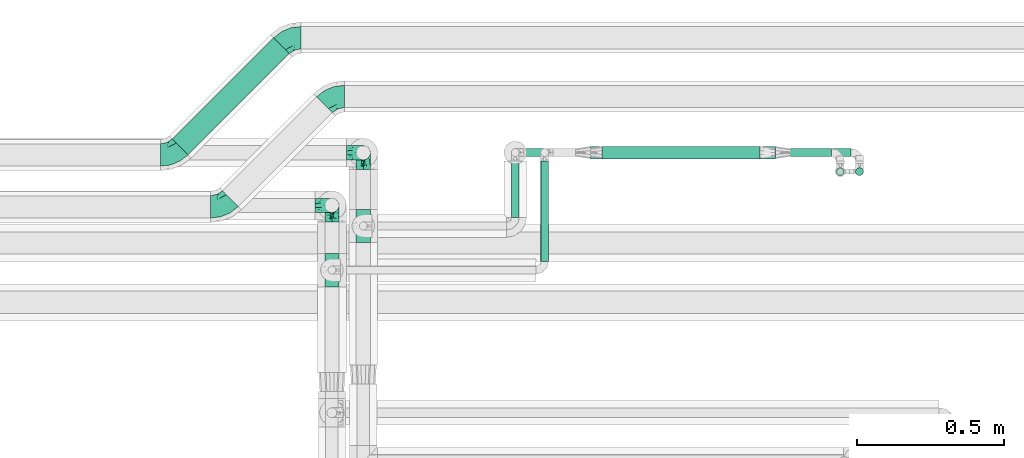
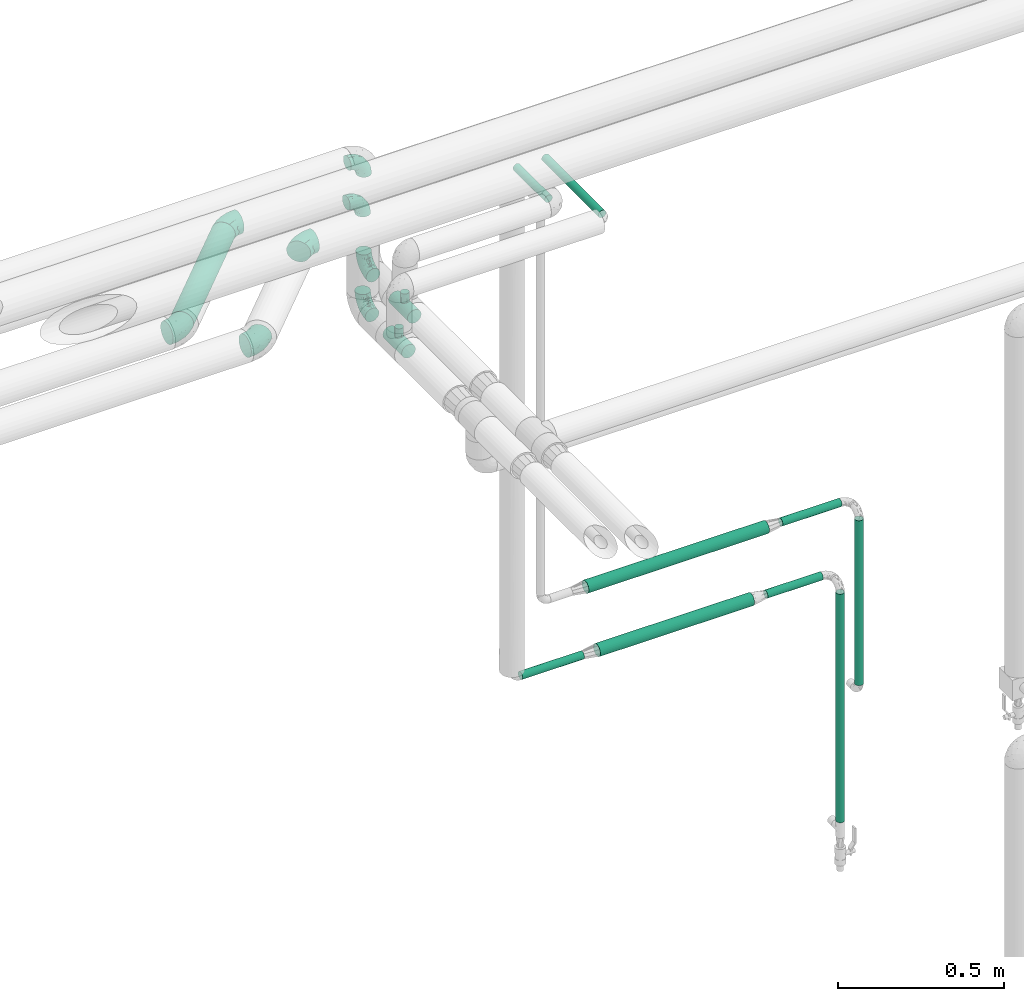
# One storey, part 655 of 827: 10 flow fittings, 10 flow segments.
"""IFC2X3 building model written with IfcOpenShell, lengths in millimetres."""

from ifc_helpers import new_model, entity, si_unit, converted_unit, derived_unit, direction, frame, origin, origin_2d_with_axis, place, context, subcontext, project, spatial, circle, extrude, faceted_brep, source, transform, mapped, material, type_object, type_shapes, element, save


model = new_model("IFC2X3")

# Units and contexts
model_context = context("Model", 3, precision=0.01, world=origin(), true_north=direction((6.12303176911189e-17, 1.0)))
body_context = subcontext(model_context, "Body", "Model", "MODEL_VIEW")
ifc_project = project(units=[si_unit("LENGTHUNIT", "METRE", prefix="MILLI"), si_unit("AREAUNIT", "SQUARE_METRE"), si_unit("VOLUMEUNIT", "CUBIC_METRE"), converted_unit("PLANEANGLEUNIT", "DEGREE", entity("IfcRatioMeasure", 0.0174532925199433), si_unit("PLANEANGLEUNIT", "RADIAN"), dimensions=[0, 0, 0, 0, 0, 0, 0]), si_unit("MASSUNIT", "GRAM", prefix="KILO"), derived_unit("MASSDENSITYUNIT", [(si_unit("MASSUNIT", "GRAM", prefix="KILO"), 1), (si_unit("LENGTHUNIT", "METRE"), -3)]), derived_unit("MOMENTOFINERTIAUNIT", [(si_unit("LENGTHUNIT", "METRE"), 4)]), si_unit("TIMEUNIT", "SECOND"), si_unit("FREQUENCYUNIT", "HERTZ"), si_unit("THERMODYNAMICTEMPERATUREUNIT", "DEGREE_CELSIUS"), derived_unit("THERMALTRANSMITTANCEUNIT", [(si_unit("MASSUNIT", "GRAM", prefix="KILO"), 1), (si_unit("THERMODYNAMICTEMPERATUREUNIT", "KELVIN"), -1), (si_unit("TIMEUNIT", "SECOND"), -3)]), derived_unit("VOLUMETRICFLOWRATEUNIT", [(si_unit("LENGTHUNIT", "METRE"), 3), (si_unit("TIMEUNIT", "SECOND"), -1)]), derived_unit("MASSFLOWRATEUNIT", [(si_unit("MASSUNIT", "GRAM", prefix="KILO"), 1), (si_unit("TIMEUNIT", "SECOND"), -1)]), derived_unit("ROTATIONALFREQUENCYUNIT", [(si_unit("TIMEUNIT", "SECOND"), -1)]), si_unit("ELECTRICCURRENTUNIT", "AMPERE"), si_unit("ELECTRICVOLTAGEUNIT", "VOLT"), si_unit("POWERUNIT", "WATT"), si_unit("FORCEUNIT", "NEWTON", prefix="KILO"), si_unit("ILLUMINANCEUNIT", "LUX"), si_unit("LUMINOUSFLUXUNIT", "LUMEN"), si_unit("LUMINOUSINTENSITYUNIT", "CANDELA"), derived_unit("USERDEFINED", [(si_unit("MASSUNIT", "GRAM", prefix="KILO"), -1), (si_unit("LENGTHUNIT", "METRE"), -2), (si_unit("TIMEUNIT", "SECOND"), 3), (si_unit("LUMINOUSFLUXUNIT", "LUMEN"), 1)]), derived_unit("LINEARVELOCITYUNIT", [(si_unit("LENGTHUNIT", "METRE"), 1), (si_unit("TIMEUNIT", "SECOND"), -1)]), si_unit("PRESSUREUNIT", "PASCAL"), derived_unit("USERDEFINED", [(si_unit("LENGTHUNIT", "METRE"), -2), (si_unit("MASSUNIT", "GRAM", prefix="KILO"), 1), (si_unit("TIMEUNIT", "SECOND"), -2)]), derived_unit("LINEARFORCEUNIT", [(si_unit("MASSUNIT", "GRAM", prefix="KILO"), 1), (si_unit("LENGTHUNIT", "METRE"), 1), (si_unit("TIMEUNIT", "SECOND"), -2), (si_unit("LENGTHUNIT", "METRE"), -1)]), derived_unit("PLANARFORCEUNIT", [(si_unit("MASSUNIT", "GRAM", prefix="KILO"), 1), (si_unit("LENGTHUNIT", "METRE"), 1), (si_unit("TIMEUNIT", "SECOND"), -2), (si_unit("LENGTHUNIT", "METRE"), -2)])], contexts=[model_context])

# Site, building, storey
site_placement = place(None, origin())
site = spatial("IfcSite", under=ifc_project, at=site_placement, CompositionType="ELEMENT")
building_placement = place(site_placement, origin())
building = spatial("IfcBuilding", under=site, at=building_placement, CompositionType="ELEMENT")
storey_placement = place(building_placement, frame((0.0, 0.0, 28200.0)))
storey = spatial("IfcBuildingStorey", under=building, at=storey_placement, Name="08", CompositionType="ELEMENT", Elevation=28200.0)

# Flow segments
pipe_segment_type_1 = type_object("IfcPipeSegmentType", PredefinedType="NOTDEFINED")
flow_segment_1_placement = place(storey_placement, frame((40825.06, 19107.08, 2960.4)))
element("IfcFlowSegment", 1, at=flow_segment_1_placement, inside=storey, type_object=pipe_segment_type_1, context=body_context, shape_type="SweptSolid", body=[
    extrude(circle(Radius=38.0, at=origin_2d_with_axis()), frame((28.47, 28.47, 39.6), z_axis=(0.707106781186507, 0.707106781186588, 0.0), x_axis=(-0.707106781186588, 0.707106781186507, 0.0)), (0.0, 0.0, 1.0), 486.299423149117),
])
pipe_segment_type_2 = type_object("IfcPipeSegmentType", PredefinedType="NOTDEFINED")
flow_segment_2_placement = place(storey_placement, frame((42877.5, 19101.22, 1284.96)))
element("IfcFlowSegment", 2, at=flow_segment_2_placement, inside=storey, type_object=pipe_segment_type_2, context=body_context, shape_type="SweptSolid", body=[
    extrude(circle(Radius=13.4, at=origin_2d_with_axis()), frame((192.75, 15.0, 15.0), z_axis=(-0.99999996769555, 2.91806022780678e-05, 0.000252502262228992), x_axis=(-2.91806032083074e-05, -1.0, 0.0)), (0.0, 0.0, 1.0), 192.748184386315),
])
flow_segment_3_placement = place(storey_placement, frame((42929.4, 19101.23, 1532.5)))
element("IfcFlowSegment", 3, at=flow_segment_3_placement, inside=storey, type_object=pipe_segment_type_2, context=body_context, shape_type="SweptSolid", body=[
    extrude(circle(Radius=13.4, at=origin_2d_with_axis()), frame((0.0, 15.0, 15.0), z_axis=(1.0, 1.05516982969305e-05, 0.0), x_axis=(-1.05516982969305e-05, 1.0, 0.0)), (0.0, 0.0, 1.0), 206.372230545777),
])
flow_segment_4_placement = place(storey_placement, frame((43084.36, 19036.22, 429.0)))
element("IfcFlowSegment", 4, at=flow_segment_4_placement, inside=storey, type_object=pipe_segment_type_2, context=body_context, shape_type="SweptSolid", body=[
    extrude(circle(Radius=13.4, at=origin_2d_with_axis()), frame((15.0, 15.0, 0.0)), (0.0, 0.0, 1.0), 841.851330356541),
])
flow_segment_5_placement = place(storey_placement, frame((43149.88, 19036.23, 910.98)))
element("IfcFlowSegment", 5, at=flow_segment_5_placement, inside=storey, type_object=pipe_segment_type_2, context=body_context, shape_type="SweptSolid", body=[
    extrude(circle(Radius=13.4, at=origin_2d_with_axis()), frame((15.0, 15.0, 0.0), z_axis=(0.0, 0.0, 1.0), x_axis=(-1.0, 0.0, 0.0)), (0.0, 0.0, 1.0), 607.424999999951),
])
flow_segment_6_placement = place(storey_placement, frame((42078.41, 18745.32, 3185.0)))
element("IfcFlowSegment", 6, at=flow_segment_6_placement, inside=storey, type_object=pipe_segment_type_2, context=body_context, shape_type="SweptSolid", body=[
    extrude(circle(Radius=13.4, at=origin_2d_with_axis()), frame((15.0, 0.0, 15.0), z_axis=(0.0, 1.0, 0.0), x_axis=(-1.0, 0.0, 0.0)), (0.0, 0.0, 1.0), 341.800000000024),
])
flow_segment_7_placement = place(storey_placement, frame((42289.4, 19093.47, 1277.25)))
element("IfcFlowSegment", 7, at=flow_segment_7_placement, inside=storey, type_object=pipe_segment_type_2, context=body_context, shape_type="SweptSolid", body=[
    extrude(circle(Radius=21.15, at=origin_2d_with_axis()), frame((0.0, 22.75, 22.75), z_axis=(1.0, 9.60419523370108e-06, 2.42912123720012e-05), x_axis=(-9.60419523653462e-06, 1.0, 0.0)), (0.0, 0.0, 1.0), 537.101091228585),
])
flow_segment_8_placement = place(storey_placement, frame((42022.5, 19101.22, 1285.0)))
element("IfcFlowSegment", 8, at=flow_segment_8_placement, inside=storey, type_object=pipe_segment_type_2, context=body_context, shape_type="SweptSolid", body=[
    extrude(circle(Radius=13.4, at=origin_2d_with_axis()), frame((0.0, 15.0, 15.0), z_axis=(1.0, 5.15660437166911e-06, 0.0), x_axis=(5.15660437166911e-06, -1.0, 0.0)), (0.0, 0.0, 1.0), 215.900000016032),
])
flow_segment_9_placement = place(storey_placement, frame((42249.4, 19093.47, 1524.75)))
element("IfcFlowSegment", 9, at=flow_segment_9_placement, inside=storey, type_object=pipe_segment_type_2, context=body_context, shape_type="SweptSolid", body=[
    extrude(circle(Radius=21.15, at=origin_2d_with_axis()), frame((0.0, 22.75, 22.75), z_axis=(1.0, -1.07992959138663e-06, 0.0), x_axis=(-1.07992959138663e-06, -1.0, 0.0)), (0.0, 0.0, 1.0), 629.000000003368),
])
flow_segment_10_placement = place(storey_placement, frame((41978.41, 18895.32, 3185.0)))
element("IfcFlowSegment", 10, at=flow_segment_10_placement, inside=storey, type_object=pipe_segment_type_2, context=body_context, shape_type="SweptSolid", body=[
    extrude(circle(Radius=13.4, at=origin_2d_with_axis()), frame((15.0, 0.0, 15.0), z_axis=(0.0, 1.0, 0.0), x_axis=(-1.0, 0.0, 0.0)), (0.0, 0.0, 1.0), 191.79873130015),
])

# Flow fittings
ifc_material = material()
pipe_fitting_type_1 = type_object("IfcPipeFittingType", Name="ADSK_1", PredefinedType="NOTDEFINED", material=ifc_material)
shared_shape_1 = source(origin(), body_context, "Body", "Brep", [
    faceted_brep([(-57.0, 12.07, -20.91), (-57.0, 6.25, -23.33), (-57.0, 0.0, -24.15), (-57.0, -6.25, -23.33), (-57.0, -12.08, -20.91), (-57.0, -17.08, -17.08), (-57.0, -20.91, -12.08), (-57.0, -23.33, -6.25), (-57.0, -24.15, 0.0), (-57.0, -23.33, 6.25), (-57.0, -20.91, 12.07), (-57.0, -17.08, 17.08), (-57.0, -12.08, 20.91), (-57.0, -6.25, 23.33), (-57.0, 0.0, 24.15), (-57.0, 6.25, 23.33), (-57.0, 12.07, 20.91), (-57.0, 17.08, 17.08), (-57.0, 20.91, 12.07), (-57.0, 23.33, 6.25), (-57.0, 24.15, 0.0), (-57.0, 23.33, -6.25), (-57.0, 20.91, -12.08), (-57.0, 17.08, -17.08), (0.0, 57.0, -24.15), (-6.25, 57.0, -23.33), (-12.07, 57.0, -20.91), (-17.08, 57.0, -17.08), (-20.91, 57.0, -12.08), (-23.33, 57.0, -6.25), (-24.15, 57.0, 0.0), (-23.33, 57.0, 6.25), (-20.91, 57.0, 12.07), (-17.08, 57.0, 17.08), (-12.07, 57.0, 20.91), (-6.25, 57.0, 23.33), (0.0, 57.0, 24.15), (6.25, 57.0, 23.33), (12.08, 57.0, 20.91), (17.08, 57.0, 17.08), (20.91, 57.0, 12.07), (23.33, 57.0, 6.25), (24.15, 57.0, 0.0), (23.33, 57.0, -6.25), (20.91, 57.0, -12.08), (17.08, 57.0, -17.08), (12.08, 57.0, -20.91), (6.25, 57.0, -23.33), (14.9, 21.14, 6.17), (13.61, 24.64, 12.48), (6.23, 8.95, 8.98), (-41.47, -21.06, 0.0), (-41.92, -18.38, 13.72), (-24.64, -13.61, 12.48), (-37.37, -13.24, 18.15), (-6.8, -4.93, 8.18), (-21.76, -15.19, 6.22), (-12.78, -9.18, 0.0), (-37.73, -20.51, 7.75), (-7.38, 7.38, 20.24), (-23.37, -4.26, 20.42), (-11.9, -3.19, 15.86), (-42.14, -8.7, 21.82), (13.24, 37.37, 18.15), (9.33, 23.53, 16.85), (4.26, 23.37, 20.42), (2.77, 10.92, 15.55), (-29.46, 0.91, 23.52), (-44.13, 20.56, 15.69), (-39.25, 26.33, 10.88), (-49.02, 22.92, 9.96), (-34.58, 23.87, 17.15), (-15.8, 6.8, 22.81), (-8.67, 20.47, 23.88), (-18.12, 12.9, 24.08), (-48.29, 14.92, 19.65), (-44.06, -2.85, 23.78), (-9.23, 48.95, 22.58), (-3.78, 42.74, 24.07), (-40.34, 4.26, 24.09), (-44.02, 26.14, 5.46), (-44.04, 9.88, 22.74), (-4.95, 16.87, 22.52), (-2.75, 1.43, 12.5), (-25.48, 40.98, 10.71), (20.51, 37.73, 7.75), (18.38, 41.92, 13.72), (8.7, 42.14, 21.82), (-25.95, -17.97, 0.0), (2.85, 44.06, 23.78), (21.06, 41.47, 0.0), (17.97, 25.95, 0.0), (-24.04, -9.27, 17.13), (-33.26, 33.26, 5.86), (-28.55, 40.57, 0.0), (-40.57, 28.55, 0.0), (-25.29, 47.19, 4.06), (-27.01, 31.1, 16.77), (-15.7, 43.95, 19.9), (-20.27, 45.22, 15.61), (-30.53, 31.98, 12.64), (-11.28, 38.33, 22.92), (-9.97, 27.88, 24.09), (-20.15, 30.26, 21.25), (-31.25, 11.75, 23.64), (-28.75, 7.23, 24.15), (-29.53, 18.06, 22.27), (-28.44, 24.21, 20.02), (-37.55, 17.7, 20.26), (-15.88, 29.25, 22.99), (-20.82, 20.82, 23.44), (-0.91, 29.46, 23.52), (-13.5, -7.67, 12.04), (1.49, 1.56, 5.16), (8.86, 10.35, 4.59), (0.38, -0.38, 0.0), (9.18, 12.78, 0.0), (-37.37, -13.24, -18.15), (8.86, 10.35, -4.59), (-45.22, 20.27, -15.61), (-43.95, 15.7, -19.9), (-38.33, 11.28, -22.92), (-48.95, 9.23, -22.58), (-47.19, 25.29, -4.06), (-33.26, 33.26, -5.86), (18.38, 41.92, -13.72), (-30.26, 20.15, -21.25), (2.85, 44.06, -23.78), (-4.26, 40.34, -24.09), (-40.98, 25.48, -10.71), (-41.92, -18.38, -13.72), (9.25, 23.5, -16.92), (4.26, 23.37, -20.42), (13.24, 37.37, -18.15), (-37.73, -20.51, -7.75), (-11.75, 31.25, -23.64), (-7.23, 28.75, -24.15), (-12.9, 18.12, -24.08), (8.7, 42.14, -21.82), (-44.06, -2.85, -23.78), (-6.8, 15.8, -22.81), (-20.47, 8.67, -23.88), (-24.64, -13.61, -12.48), (-42.74, 3.78, -24.07), (-18.06, 29.53, -22.27), (-24.21, 28.44, -20.02), (-27.88, 9.97, -24.09), (-31.1, 27.01, -16.77), (-26.14, 44.02, -5.46), (14.9, 21.14, -6.17), (20.51, 37.73, -7.75), (-9.88, 44.04, -22.74), (-20.56, 44.13, -15.69), (-21.76, -15.19, -6.22), (-13.5, -7.67, -12.04), (-24.14, -9.76, -16.74), (-11.9, -3.19, -15.86), (-14.92, 48.29, -19.65), (-23.37, -4.26, -20.42), (-0.91, 29.46, -23.52), (-26.33, 39.25, -10.88), (-23.87, 34.58, -17.15), (-42.14, -8.7, -21.82), (-22.92, 49.02, -9.96), (13.61, 24.64, -12.48), (-31.98, 30.53, -12.64), (-16.87, 4.95, -22.52), (-17.7, 37.55, -20.26), (-29.25, 15.88, -22.99), (-20.82, 20.82, -23.44), (-29.46, 0.91, -23.52), (-7.38, 7.38, -20.24), (2.77, 10.92, -15.55), (6.23, 8.95, -8.98), (-6.8, -4.93, -8.18), (-2.81, 1.41, -12.54), (1.49, 1.56, -5.16)], [[[0, 1, 2, 3, 4, 5, 6, 7, 8, 9, 10, 11, 12, 13, 14, 15, 16, 17, 18, 19, 20, 21, 22, 23]], [[24, 25, 26, 27, 28, 29, 30, 31, 32, 33, 34, 35, 36, 37, 38, 39, 40, 41, 42, 43, 44, 45, 46, 47]], [[48, 49, 50]], [[9, 8, 51]], [[52, 53, 54]], [[55, 56, 57]], [[10, 58, 52]], [[9, 58, 10]], [[59, 60, 61]], [[54, 12, 11]], [[54, 62, 12]], [[63, 39, 38]], [[64, 65, 66]], [[62, 60, 67]], [[68, 69, 70]], [[71, 69, 68]], [[72, 73, 74]], [[16, 75, 17]], [[13, 76, 14]], [[35, 77, 78]], [[14, 79, 15]], [[17, 68, 18]], [[14, 76, 79]], [[20, 19, 80]], [[70, 19, 18]], [[81, 15, 79]], [[15, 81, 16]], [[73, 72, 82]], [[66, 83, 50]], [[32, 31, 84]], [[85, 86, 49]], [[63, 87, 65]], [[56, 58, 88]], [[36, 89, 37]], [[85, 41, 40]], [[36, 35, 78]], [[90, 41, 85]], [[40, 39, 86]], [[12, 62, 13]], [[86, 85, 40]], [[48, 85, 49]], [[85, 91, 90]], [[87, 38, 37]], [[92, 60, 54]], [[80, 69, 93]], [[93, 94, 95]], [[10, 52, 11]], [[94, 96, 30]], [[97, 98, 99]], [[80, 93, 95]], [[100, 97, 84]], [[99, 98, 33]], [[101, 102, 78]], [[103, 101, 98]], [[96, 31, 30]], [[77, 98, 101]], [[77, 35, 34]], [[34, 33, 98]], [[9, 51, 58]], [[87, 63, 38]], [[104, 105, 74]], [[106, 103, 107]], [[106, 81, 104]], [[75, 68, 17]], [[108, 107, 71]], [[33, 32, 99]], [[109, 103, 110]], [[101, 109, 102]], [[89, 78, 111]], [[53, 52, 58]], [[54, 11, 52]], [[60, 62, 54]], [[88, 58, 51]], [[76, 62, 67]], [[53, 112, 92]], [[60, 59, 72]], [[39, 63, 86]], [[49, 86, 63]], [[89, 87, 37]], [[42, 41, 90]], [[111, 82, 65]], [[111, 65, 87]], [[65, 59, 66]], [[104, 81, 79]], [[75, 81, 108]], [[32, 84, 99]], [[97, 99, 84]], [[98, 97, 103]], [[106, 107, 108]], [[74, 102, 110]], [[111, 78, 102]], [[74, 110, 104]], [[74, 67, 72]], [[61, 92, 112]], [[66, 59, 61]], [[56, 53, 58]], [[66, 50, 49]], [[61, 112, 83]], [[66, 49, 64]], [[78, 89, 36]], [[87, 89, 111]], [[62, 76, 13]], [[79, 76, 67]], [[100, 93, 69]], [[96, 93, 84]], [[55, 113, 50]], [[113, 114, 50]], [[104, 79, 105]], [[106, 104, 110]], [[20, 80, 95]], [[85, 48, 91]], [[115, 114, 113]], [[116, 91, 48]], [[70, 80, 19]], [[93, 96, 94]], [[84, 31, 96]], [[103, 106, 110]], [[81, 106, 108]], [[103, 97, 107]], [[71, 107, 97]], [[71, 97, 100]], [[108, 71, 68]], [[79, 67, 105]], [[67, 74, 105]], [[115, 113, 57]], [[112, 56, 55]], [[56, 88, 57]], [[60, 72, 67]], [[82, 72, 59]], [[65, 82, 59]], [[82, 111, 73]], [[111, 102, 73]], [[102, 74, 73]], [[81, 75, 16]], [[68, 75, 108]], [[68, 70, 18]], [[80, 70, 69]], [[98, 77, 34]], [[78, 77, 101]], [[93, 100, 84]], [[71, 100, 69]], [[102, 109, 110]], [[101, 103, 109]], [[53, 92, 54]], [[61, 60, 92]], [[56, 112, 53]], [[83, 112, 55]], [[50, 83, 55]], [[61, 83, 66]], [[49, 63, 64]], [[65, 64, 63]], [[57, 113, 55]], [[114, 115, 116]], [[116, 48, 114]], [[48, 50, 114]], [[117, 5, 4]], [[116, 115, 118]], [[119, 120, 23]], [[121, 122, 120]], [[95, 123, 20]], [[0, 23, 120]], [[124, 95, 94]], [[125, 45, 44]], [[121, 120, 126]], [[24, 127, 128]], [[22, 21, 129]], [[0, 122, 1]], [[5, 117, 130]], [[131, 132, 133]], [[134, 88, 51]], [[135, 136, 137]], [[6, 5, 130]], [[46, 138, 47]], [[139, 3, 2]], [[140, 141, 137]], [[6, 134, 7]], [[134, 130, 142]], [[143, 2, 1]], [[144, 126, 145]], [[121, 146, 143]], [[147, 120, 119]], [[94, 148, 124]], [[149, 150, 91]], [[30, 29, 148]], [[151, 25, 128]], [[27, 152, 28]], [[134, 153, 88]], [[154, 155, 156]], [[27, 26, 157]], [[151, 26, 25]], [[155, 158, 156]], [[24, 47, 127]], [[1, 122, 143]], [[138, 132, 159]], [[160, 152, 161]], [[24, 128, 25]], [[46, 133, 138]], [[162, 117, 4]], [[148, 160, 124]], [[152, 160, 163]], [[154, 142, 155]], [[45, 125, 133]], [[133, 46, 45]], [[125, 164, 133]], [[51, 7, 134]], [[42, 90, 43]], [[165, 147, 129]], [[153, 134, 142]], [[43, 150, 44]], [[162, 4, 3]], [[141, 140, 166]], [[117, 162, 158]], [[163, 29, 28]], [[43, 90, 150]], [[123, 21, 20]], [[144, 151, 135]], [[157, 152, 27]], [[167, 145, 161]], [[23, 22, 119]], [[168, 126, 169]], [[121, 168, 146]], [[139, 143, 170]], [[142, 130, 117]], [[8, 7, 51]], [[134, 6, 130]], [[139, 162, 3]], [[170, 166, 158]], [[170, 158, 162]], [[158, 171, 156]], [[44, 150, 125]], [[91, 150, 90]], [[164, 125, 150]], [[132, 138, 133]], [[127, 138, 159]], [[131, 164, 172]], [[132, 171, 140]], [[135, 151, 128]], [[157, 151, 167]], [[22, 129, 119]], [[147, 119, 129]], [[120, 147, 126]], [[144, 145, 167]], [[137, 146, 169]], [[170, 143, 146]], [[137, 169, 135]], [[137, 159, 140]], [[171, 172, 156]], [[173, 174, 175]], [[156, 175, 154]], [[174, 57, 153]], [[132, 172, 171]], [[172, 164, 173]], [[143, 139, 2]], [[162, 139, 170]], [[138, 127, 47]], [[128, 127, 159]], [[165, 124, 160]], [[123, 124, 129]], [[149, 173, 164]], [[176, 174, 173]], [[135, 128, 136]], [[144, 135, 169]], [[150, 149, 164]], [[176, 118, 115]], [[149, 91, 116]], [[30, 148, 94]], [[163, 148, 29]], [[124, 123, 95]], [[129, 21, 123]], [[126, 144, 169]], [[151, 144, 167]], [[126, 147, 145]], [[161, 145, 147]], [[161, 147, 165]], [[167, 161, 152]], [[128, 159, 136]], [[159, 137, 136]], [[154, 153, 142]], [[132, 140, 159]], [[174, 176, 57]], [[57, 88, 153]], [[166, 140, 171]], [[158, 166, 171]], [[166, 170, 141]], [[170, 146, 141]], [[146, 137, 141]], [[151, 157, 26]], [[152, 157, 167]], [[152, 163, 28]], [[148, 163, 160]], [[120, 122, 0]], [[143, 122, 121]], [[124, 165, 129]], [[161, 165, 160]], [[146, 168, 169]], [[121, 126, 168]], [[142, 117, 155]], [[158, 155, 117]], [[175, 156, 172]], [[153, 154, 174]], [[173, 175, 172]], [[174, 154, 175]], [[164, 131, 133]], [[172, 132, 131]], [[176, 173, 118]], [[57, 176, 115]], [[173, 149, 118]], [[149, 116, 118]]]),
])
type_shapes(pipe_fitting_type_1, [shared_shape_1])
for number, where, z_axis, x_axis, name in (
    (11, (41369.37, 18936.46, 3000.0), (1.0, 0.0, 0.0), (0.0, 1.0, 0.0), "ADSK_1"),
    (12, (41369.37, 18936.46, 3399.89), (1.42382432840745e-05, -1.0, 0.0), (0.0, 0.0, 1.0), "ADSK_1"),
    (13, (41476.22, 19115.49, 3000.0), (1.0, 0.0, 0.0), (0.0, 1.0, 0.0), "ADSK_1"),
    (14, (41476.22, 19115.49, 3399.89), (0.0, -1.0, 0.0), (0.0, 0.0, 1.0), "ADSK_1"),
):
    element("IfcFlowFitting", number, at=place(storey_placement, frame(where, z_axis=z_axis, x_axis=x_axis)), inside=storey, type_object=pipe_fitting_type_1, material=ifc_material, Name=name, ObjectType="ADSK_1", context=body_context, shape_type="MappedRepresentation", body=[
        mapped(shared_shape_1, transform((0.0, 0.0, 0.0), scale=1.0)),
    ])
pipe_fitting_type_2 = type_object("IfcPipeFittingType", Name="ADSK_1", PredefinedType="NOTDEFINED", material=ifc_material)
shared_shape_2 = source(origin(), body_context, "Body", "Brep", [
    faceted_brep([(-57.0, 12.07, -20.91), (-57.0, 6.25, -23.33), (-57.0, 0.0, -24.15), (-57.0, -6.25, -23.33), (-57.0, -12.08, -20.91), (-57.0, -17.08, -17.08), (-57.0, -20.91, -12.08), (-57.0, -23.33, -6.25), (-57.0, -24.15, 0.0), (-57.0, -23.33, 6.25), (-57.0, -20.91, 12.07), (-57.0, -17.08, 17.08), (-57.0, -12.08, 20.91), (-57.0, -6.25, 23.33), (-57.0, 0.0, 24.15), (-57.0, 6.25, 23.33), (-57.0, 12.07, 20.91), (-57.0, 17.08, 17.08), (-57.0, 20.91, 12.07), (-57.0, 23.33, 6.25), (-57.0, 24.15, 0.0), (-57.0, 23.33, -6.25), (-57.0, 20.91, -12.08), (-57.0, 17.08, -17.08), (57.0, 0.0, -24.15), (57.0, 6.25, -23.33), (57.0, 12.07, -20.91), (57.0, 17.08, -17.08), (57.0, 20.91, -12.08), (57.0, 23.33, -6.25), (57.0, 24.15, 0.0), (57.0, 23.33, 6.25), (57.0, 20.91, 12.07), (57.0, 17.08, 17.08), (57.0, 12.07, 20.91), (57.0, 6.25, 23.33), (57.0, 0.0, 24.15), (57.0, -6.25, 23.33), (57.0, -12.08, 20.91), (57.0, -17.08, 17.08), (57.0, -20.91, 12.07), (57.0, -23.33, 6.25), (57.0, -24.15, 0.0), (57.0, -23.33, -6.25), (57.0, -20.91, -12.08), (57.0, -17.08, -17.08), (57.0, -12.08, -20.91), (57.0, -6.25, -23.33), (12.61, -23.69, 4.67), (13.03, -23.92, 2.34), (13.45, -24.15, 0.0), (10.28, -22.54, 8.68), (2.38, -20.2, 13.24), (6.77, -21.17, 11.62), (4.58, -20.68, 12.43), (-13.45, -24.15, 0.0), (-13.03, -23.92, 2.34), (-12.61, -23.69, 4.67), (-10.28, -22.54, 8.67), (-6.77, -21.17, 11.62), (-4.58, -20.68, 12.43), (-2.38, -20.2, 13.24), (0.0, -20.2, 13.24), (2.38, -20.2, -13.24), (6.77, -21.17, -11.62), (4.58, -20.68, -12.43), (10.28, -22.54, -8.68), (12.61, -23.69, -4.67), (13.03, -23.92, -2.34), (-2.38, -20.2, -13.24), (-4.58, -20.68, -12.43), (-6.77, -21.17, -11.62), (-10.28, -22.54, -8.67), (0.0, -20.2, -13.24), (-12.61, -23.69, -4.67), (-13.03, -23.92, -2.34), (-12.99, -57.0, -3.48), (-11.65, -57.0, -6.73), (-9.51, -57.0, -9.51), (-6.72, -57.0, -11.65), (-3.48, -57.0, -12.99), (0.0, -57.0, -13.45), (3.48, -57.0, -12.99), (6.73, -57.0, -11.65), (9.51, -57.0, -9.51), (11.65, -57.0, -6.73), (12.99, -57.0, -3.48), (13.45, -57.0, 0.0), (12.99, -57.0, 3.48), (11.65, -57.0, 6.72), (9.51, -57.0, 9.51), (6.73, -57.0, 11.65), (3.48, -57.0, 12.99), (0.0, -57.0, 13.45), (-3.48, -57.0, 12.99), (-6.72, -57.0, 11.65), (-9.51, -57.0, 9.51), (-11.65, -57.0, 6.72), (-12.99, -57.0, 3.48), (-13.45, -57.0, 0.0)], [[[0, 1, 2, 3, 4, 5, 6, 7, 8, 9, 10, 11, 12, 13, 14, 15, 16, 17, 18, 19, 20, 21, 22, 23]], [[24, 25, 26, 27, 28, 29, 30, 31, 32, 33, 34, 35, 36, 37, 38, 39, 40, 41, 42, 43, 44, 45, 46, 47]], [[42, 41, 48]], [[42, 48, 49, 50]], [[41, 51, 48]], [[40, 39, 52]], [[53, 51, 40]], [[40, 52, 54, 53]], [[39, 11, 52]], [[40, 51, 41]], [[8, 55, 56, 57]], [[9, 8, 57]], [[57, 58, 9]], [[10, 59, 60, 61]], [[59, 10, 58]], [[10, 61, 11]], [[58, 10, 9]], [[11, 61, 62, 52]], [[39, 38, 12, 11]], [[14, 13, 37, 36]], [[13, 12, 38, 37]], [[15, 14, 36, 35]], [[32, 31, 19, 18]], [[17, 16, 34, 33]], [[18, 17, 33, 32]], [[35, 34, 16, 15]], [[20, 19, 31, 30]], [[29, 28, 22, 21]], [[28, 27, 23, 22]], [[30, 29, 21, 20]], [[24, 47, 3, 2]], [[1, 0, 26, 25]], [[2, 1, 25, 24]], [[27, 26, 0, 23]], [[4, 3, 47, 46]], [[46, 45, 5, 4]], [[45, 44, 63]], [[44, 64, 65, 63]], [[44, 66, 64]], [[45, 63, 5]], [[43, 42, 67]], [[67, 66, 43]], [[42, 50, 68, 67]], [[43, 66, 44]], [[6, 69, 70, 71]], [[6, 5, 69]], [[71, 72, 6]], [[5, 63, 73, 69]], [[72, 74, 7]], [[74, 8, 7]], [[8, 74, 75, 55]], [[72, 7, 6]], [[76, 77, 78, 79, 80, 81, 82, 83, 84, 85, 86, 87, 88, 89, 90, 91, 92, 93, 94, 95, 96, 97, 98, 99]], [[57, 98, 97]], [[59, 96, 95]], [[97, 96, 58]], [[91, 54, 92]], [[56, 99, 98]], [[55, 99, 56]], [[98, 57, 56]], [[58, 57, 97]], [[96, 59, 58]], [[49, 48, 88]], [[60, 59, 95]], [[94, 61, 60]], [[49, 87, 50]], [[93, 52, 62, 61]], [[91, 53, 54]], [[90, 53, 91]], [[48, 89, 88]], [[90, 89, 51]], [[52, 93, 92]], [[54, 52, 92]], [[60, 95, 94]], [[53, 90, 51]], [[51, 89, 48]], [[93, 61, 94]], [[87, 49, 88]], [[86, 68, 87]], [[81, 63, 82]], [[65, 83, 82]], [[65, 64, 83]], [[86, 67, 68]], [[67, 86, 85]], [[75, 74, 76]], [[66, 85, 84]], [[68, 50, 87]], [[67, 85, 66]], [[79, 70, 80]], [[64, 66, 84]], [[82, 63, 65]], [[64, 84, 83]], [[81, 69, 73, 63]], [[79, 71, 70]], [[78, 71, 79]], [[74, 77, 76]], [[78, 77, 72]], [[69, 81, 80]], [[70, 69, 80]], [[71, 78, 72]], [[72, 77, 74]], [[99, 75, 76]], [[75, 99, 55]]]),
])
type_shapes(pipe_fitting_type_2, [shared_shape_2])
for number, where, z_axis, x_axis, name in (
    (15, (41476.22, 18866.22, 3000.0), (1.0, 0.0, 0.0), (0.0, -1.0, 0.0), "ADSK_1"),
    (16, (41369.37, 18716.22, 3000.0), (1.0, 0.0, 0.0), (0.0, -1.0, 0.0), "ADSK_1"),
):
    element("IfcFlowFitting", number, at=place(storey_placement, frame(where, z_axis=z_axis, x_axis=x_axis)), inside=storey, type_object=pipe_fitting_type_2, material=ifc_material, Name=name, ObjectType="ADSK_1", context=body_context, shape_type="MappedRepresentation", body=[
        mapped(shared_shape_2, transform((0.0, 0.0, 0.0), scale=1.0)),
    ])
pipe_fitting_type_3 = type_object("IfcPipeFittingType", Name="ADSK_1", PredefinedType="NOTDEFINED", material=ifc_material)
shared_shape_3 = source(origin(), body_context, "Body", "Brep", [
    faceted_brep([(-39.35, 19.02, -32.95), (-39.35, 9.85, -36.75), (-39.35, 0.0, -38.05), (-39.35, -9.85, -36.75), (-39.35, -19.03, -32.95), (-39.35, -26.91, -26.91), (-39.35, -32.95, -19.03), (-39.35, -36.75, -9.85), (-39.35, -38.05, 0.0), (-39.35, -36.75, 9.85), (-39.35, -32.95, 19.02), (-39.35, -26.91, 26.91), (-39.35, -19.03, 32.95), (-39.35, -9.85, 36.75), (-39.35, 0.0, 38.05), (-39.35, 9.85, 36.75), (-39.35, 19.02, 32.95), (-39.35, 26.91, 26.91), (-39.35, 32.95, 19.02), (-39.35, 36.75, 9.85), (-39.35, 38.05, 0.0), (-39.35, 36.75, -9.85), (-39.35, 32.95, -19.03), (-39.35, 26.91, -26.91), (27.82, 27.82, -38.05), (20.86, 34.79, -36.75), (14.37, 41.28, -32.95), (8.8, 46.85, -26.91), (4.52, 51.13, -19.03), (1.84, 53.81, -9.85), (0.92, 54.73, 0.0), (1.84, 53.81, 9.85), (4.52, 51.13, 19.02), (8.8, 46.85, 26.91), (14.37, 41.28, 32.95), (20.86, 34.79, 36.75), (27.82, 27.82, 38.05), (34.79, 20.86, 36.75), (41.28, 14.37, 32.95), (46.85, 8.8, 26.91), (51.13, 4.52, 19.02), (53.81, 1.84, 9.85), (54.73, 0.92, 0.0), (53.81, 1.84, -9.85), (51.13, 4.52, -19.03), (46.85, 8.8, -26.91), (41.28, 14.37, -32.95), (34.79, 20.86, -36.75), (-16.48, -28.6, 22.48), (-9.83, -32.19, 13.52), (8.97, -21.66, 21.67), (-20.54, -35.57, 0.0), (-4.91, -33.52, 0.0), (-13.54, -34.93, 6.65), (-11.41, -20.66, 29.54), (31.88, -8.57, 22.48), (-19.69, -13.48, 34.86), (3.15, -7.61, 34.49), (12.7, 20.76, 37.8), (-14.37, -2.8, 37.58), (-4.35, 10.49, 37.89), (-23.66, 5.7, 37.8), (22.68, -6.54, 29.54), (23.46, 4.39, 34.86), (-17.67, 16.65, 35.5), (-11.48, 27.71, 30.93), (-5.05, 36.47, 26.65), (11.57, -24.66, 14.82), (11.29, -27.26, 7.35), (-19.91, 32.6, 23.86), (-16.29, 39.33, 15.52), (34.27, -15.12, 6.65), (39.68, -10.63, 0.0), (-13.09, 43.52, 7.94), (12.14, 8.18, 37.58), (29.72, -15.81, 13.52), (2.92, 25.68, 35.46), (5.55, -13.39, 30.82), (-17.56, 42.39, 0.0), (-7.75, 40.18, 21.01), (11.13, -26.87, 0.0), (27.17, -20.22, 0.0), (-14.37, -2.8, -37.58), (-13.54, -34.93, -6.65), (11.26, -27.2, -7.7), (0.72, 24.27, -35.5), (-23.66, 5.7, -37.8), (-21.52, 40.03, -7.94), (-16.29, 39.33, -15.52), (22.68, -6.54, -29.54), (-22.21, 29.36, -26.65), (29.72, -15.81, -13.52), (-22.93, 33.89, -21.01), (-8.97, 37.13, -23.86), (12.14, 8.18, -37.58), (-20.22, 16.09, -35.46), (-9.83, -32.19, -13.52), (31.88, -8.57, -22.48), (-16.48, -28.6, -22.48), (8.97, -21.66, -21.67), (8.74, -25.75, -14.99), (-11.41, -20.66, -29.54), (5.55, -13.39, -30.82), (3.15, -7.61, -34.49), (-19.69, -13.48, -34.86), (-11.48, 27.71, -30.93), (34.27, -15.12, -6.65), (12.7, 20.76, -37.8), (23.46, 4.39, -34.86), (-4.35, 10.49, -37.89)], [[[0, 1, 2, 3, 4, 5, 6, 7, 8, 9, 10, 11, 12, 13, 14, 15, 16, 17, 18, 19, 20, 21, 22, 23]], [[24, 25, 26, 27, 28, 29, 30, 31, 32, 33, 34, 35, 36, 37, 38, 39, 40, 41, 42, 43, 44, 45, 46, 47]], [[48, 49, 50]], [[51, 52, 53]], [[12, 11, 54]], [[40, 39, 55]], [[56, 54, 57]], [[48, 11, 10]], [[36, 35, 58]], [[13, 12, 56]], [[59, 60, 61]], [[14, 13, 59]], [[62, 55, 39]], [[38, 37, 63]], [[61, 15, 14]], [[16, 64, 65]], [[9, 51, 53]], [[33, 66, 34]], [[67, 49, 68]], [[65, 17, 16]], [[18, 17, 69]], [[18, 69, 70]], [[19, 18, 70]], [[41, 71, 72]], [[73, 20, 19]], [[52, 68, 53]], [[49, 53, 68]], [[16, 15, 64]], [[36, 58, 74]], [[39, 38, 62]], [[57, 74, 59]], [[74, 37, 36]], [[66, 69, 65]], [[75, 40, 55]], [[60, 58, 76]], [[62, 38, 63]], [[17, 65, 69]], [[71, 41, 75]], [[49, 48, 10]], [[61, 64, 15]], [[77, 50, 62]], [[19, 70, 73]], [[10, 9, 49]], [[78, 73, 30]], [[48, 54, 11]], [[31, 73, 70]], [[57, 63, 74]], [[69, 66, 79]], [[55, 62, 50]], [[79, 70, 69]], [[56, 59, 13]], [[35, 34, 76]], [[76, 65, 64]], [[54, 77, 57]], [[60, 59, 74]], [[75, 41, 40]], [[54, 48, 50]], [[32, 31, 70]], [[75, 55, 50]], [[65, 76, 34]], [[60, 76, 64]], [[54, 56, 12]], [[59, 56, 57]], [[74, 63, 37]], [[62, 63, 57]], [[9, 8, 51]], [[68, 52, 80, 81]], [[9, 53, 49]], [[71, 68, 81]], [[68, 75, 67]], [[72, 71, 81]], [[72, 42, 41]], [[68, 71, 75]], [[59, 61, 14]], [[64, 61, 60]], [[76, 58, 35]], [[74, 58, 60]], [[30, 73, 31]], [[73, 78, 20]], [[50, 77, 54]], [[62, 57, 77]], [[34, 66, 65]], [[79, 33, 32]], [[33, 79, 66]], [[32, 70, 79]], [[75, 50, 67]], [[49, 67, 50]], [[3, 2, 82]], [[52, 83, 84]], [[26, 25, 85]], [[2, 1, 86]], [[21, 87, 88]], [[46, 45, 89]], [[0, 23, 90]], [[44, 43, 91]], [[92, 88, 93]], [[24, 47, 94]], [[29, 28, 88]], [[1, 0, 95]], [[83, 7, 96]], [[91, 97, 44]], [[98, 99, 100]], [[98, 96, 6]], [[5, 4, 101]], [[89, 102, 103]], [[7, 6, 96]], [[5, 98, 6]], [[104, 4, 3]], [[90, 93, 105]], [[101, 98, 5]], [[28, 27, 93]], [[20, 78, 87]], [[27, 105, 93]], [[30, 29, 87]], [[102, 99, 101]], [[105, 85, 95]], [[88, 22, 21]], [[28, 93, 88]], [[104, 101, 4]], [[85, 105, 26]], [[90, 92, 93]], [[86, 82, 2]], [[27, 26, 105]], [[43, 72, 106]], [[107, 25, 24]], [[108, 47, 46]], [[7, 83, 51]], [[44, 97, 45]], [[103, 108, 89]], [[97, 89, 45]], [[109, 107, 94]], [[99, 97, 91]], [[109, 94, 82]], [[106, 72, 81]], [[108, 94, 47]], [[103, 104, 82]], [[83, 96, 84]], [[103, 82, 94]], [[100, 91, 84]], [[107, 85, 25]], [[29, 88, 87]], [[109, 86, 95]], [[98, 101, 99]], [[89, 97, 99]], [[105, 95, 0]], [[109, 95, 85]], [[82, 104, 3]], [[101, 104, 103]], [[89, 108, 46]], [[94, 108, 103]], [[51, 83, 52]], [[51, 8, 7]], [[100, 84, 96]], [[106, 84, 91]], [[84, 81, 80, 52]], [[43, 42, 72]], [[84, 106, 81]], [[43, 106, 91]], [[95, 86, 1]], [[82, 86, 109]], [[94, 107, 24]], [[85, 107, 109]], [[20, 87, 21]], [[87, 78, 30]], [[99, 102, 89]], [[101, 103, 102]], [[0, 90, 105]], [[92, 23, 22]], [[23, 92, 90]], [[22, 88, 92]], [[98, 100, 96]], [[91, 100, 99]]]),
])
type_shapes(pipe_fitting_type_3, [shared_shape_3])
for number, where, z_axis, x_axis, name in (
    (17, (41372.24, 19307.23, 3000.0), (0.0, 0.0, 1.0), (-1.0, 0.0, 0.0), "ADSK_1"),
    (18, (41225.22, 19507.23, 3000.0), (0.0, 0.0, 1.0), (-1.0, 0.0, 0.0), "ADSK_1"),
):
    element("IfcFlowFitting", number, at=place(storey_placement, frame(where, z_axis=z_axis, x_axis=x_axis)), inside=storey, type_object=pipe_fitting_type_3, material=ifc_material, Name=name, ObjectType="ADSK_1", context=body_context, shape_type="MappedRepresentation", body=[
        mapped(shared_shape_3, transform((0.0, 0.0, 0.0), scale=1.0)),
    ])
for number, where, name in (
    (19, (40825.7, 19107.72, 3000.0), "ADSK_1"),
    (20, (40996.35, 18931.35, 3000.0), "ADSK_1"),
):
    element("IfcFlowFitting", number, at=place(storey_placement, frame(where)), inside=storey, type_object=pipe_fitting_type_3, material=ifc_material, Name=name, ObjectType="ADSK_1", context=body_context, shape_type="MappedRepresentation", body=[
        mapped(shared_shape_3, transform((0.0, 0.0, 0.0), scale=1.0)),
    ])

save(model, "model.ifc")
